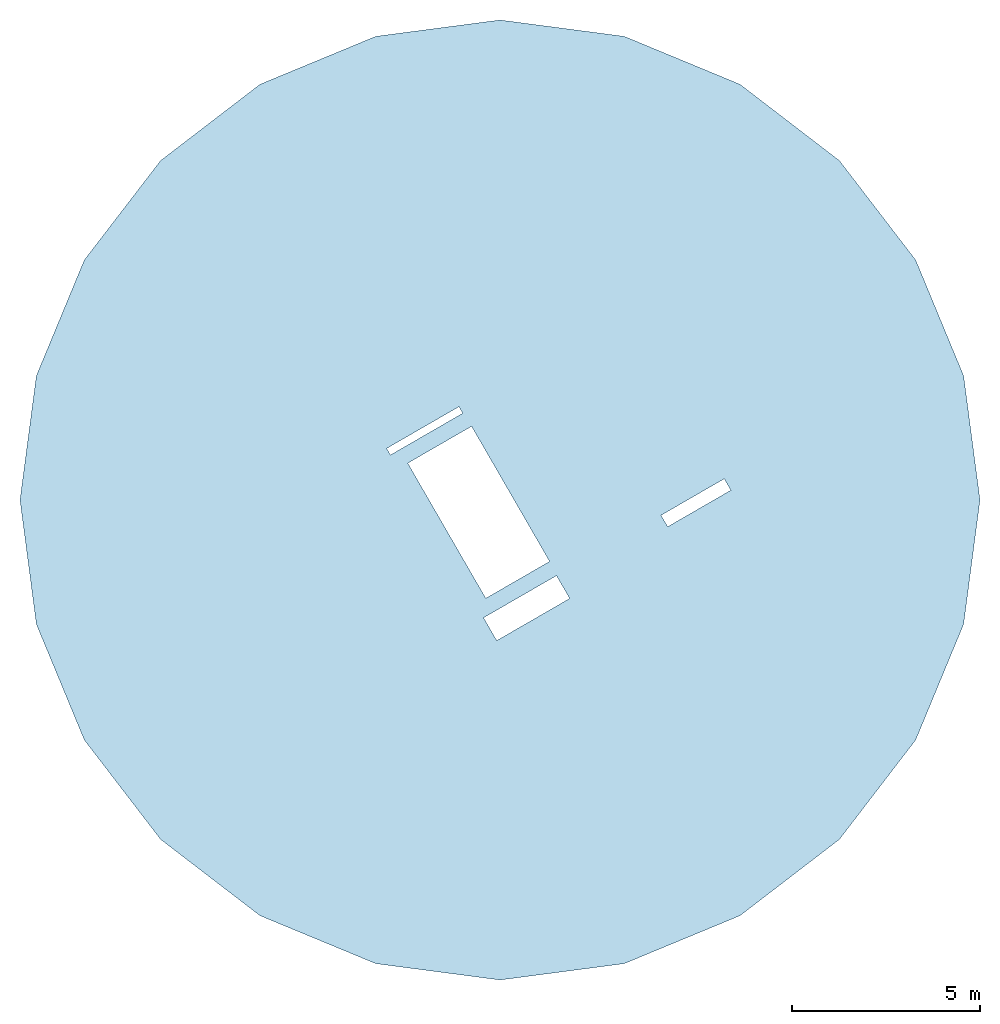
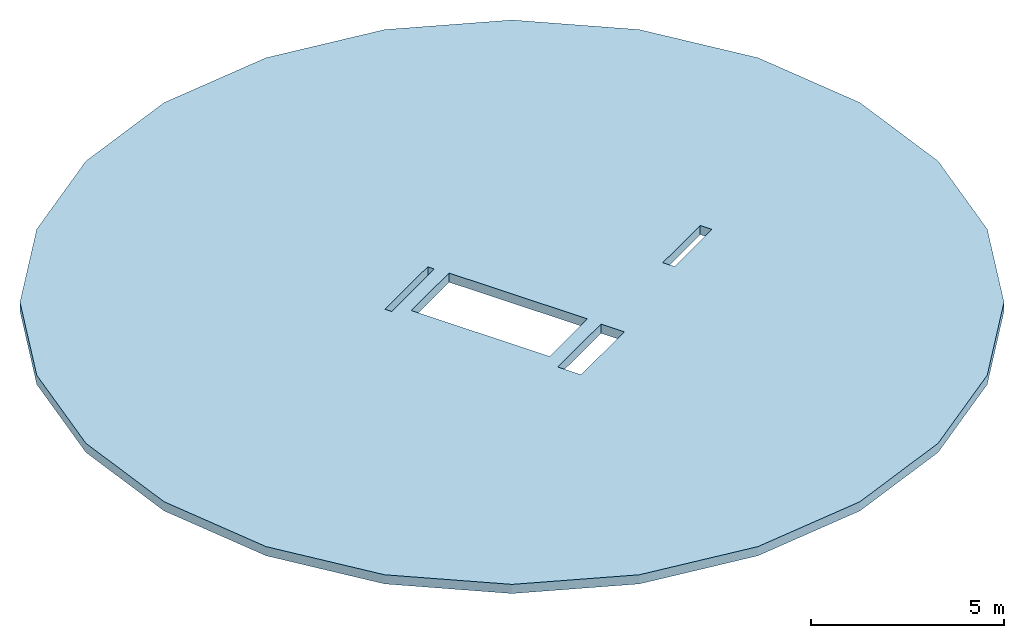
# One storey: 1 slab, 4 openings.
"""IFC2X3 building model written with IfcOpenShell, lengths in millimetres."""

from ifc_helpers import new_model, entity, si_unit, converted_unit, derived_unit, direction, frame, frame_2d, origin, origin_with_axes, place, context, subcontext, project, spatial, polyline, rectangle, outline, extrude, material, layer, layer_set, layer_usage, type_object, element, save


model = new_model("IFC2X3")

# Units and contexts
model_context = context("Model", 3, precision=0.01, world=origin(), true_north=direction((6.12303176911189e-17, 1.0)))
plan_context = context("Plan", 3, precision=0.01, world=origin(), true_north=direction((6.12303176911189e-17, 1.0)))
body_context = subcontext(model_context, "Body", "Model", "MODEL_VIEW")
ifc_project = project(units=[converted_unit("PLANEANGLEUNIT", "DEGREE", entity("IfcPositiveLengthMeasure", 0.0174532925239284), si_unit("PLANEANGLEUNIT", "RADIAN"), dimensions=[0, 0, 0, 0, 0, 0, 0]), si_unit("AREAUNIT", "SQUARE_METRE", prefix="MILLI"), si_unit("LENGTHUNIT", "METRE", prefix="MILLI"), si_unit("MASSUNIT", "GRAM", prefix="KILO"), si_unit("POWERUNIT", "WATT"), si_unit("PRESSUREUNIT", "PASCAL"), si_unit("FORCEUNIT", "NEWTON", prefix="KILO"), si_unit("ELECTRICVOLTAGEUNIT", "VOLT"), si_unit("ELECTRICCURRENTUNIT", "AMPERE"), si_unit("THERMODYNAMICTEMPERATUREUNIT", "DEGREE_CELSIUS"), si_unit("TIMEUNIT", "SECOND"), si_unit("VOLUMEUNIT", "CUBIC_METRE", prefix="MILLI"), derived_unit("LINEARVELOCITYUNIT", [(si_unit("LENGTHUNIT", "METRE"), 1), (si_unit("TIMEUNIT", "SECOND"), -1)]), derived_unit("VOLUMETRICFLOWRATEUNIT", [(si_unit("VOLUMEUNIT", "CUBIC_METRE"), 1), (si_unit("TIMEUNIT", "SECOND"), -1)]), derived_unit("THERMALTRANSMITTANCEUNIT", [(si_unit("POWERUNIT", "WATT"), 1), (si_unit("THERMODYNAMICTEMPERATUREUNIT", "KELVIN"), -1), (si_unit("AREAUNIT", "SQUARE_METRE"), -1)]), derived_unit("SOUNDPRESSUREUNIT", [(si_unit("PRESSUREUNIT", "PASCAL"), 1)])], contexts=[model_context, plan_context])

# Site, building, storey
site_placement = place(None, origin_with_axes())
site = spatial("IfcSite", under=ifc_project, at=site_placement, CompositionType="ELEMENT")
building_placement = place(site_placement, origin_with_axes())
building = spatial("IfcBuilding", under=site, at=building_placement, CompositionType="ELEMENT")
storey_placement = place(building_placement, frame((0.0, 0.0, 31510.0), z_axis=(0.0, 0.0, 1.0), x_axis=(1.0, 0.0, 0.0)))
storey = spatial("IfcBuildingStorey", under=building, at=storey_placement, Name="07 zevende verdieping", CompositionType="ELEMENT", Elevation=31510.0)

# Slab, openings
ifc_material = material()
ifc_layer = layer(ifc_material, 290.0)
ifc_layer_set = layer_set([ifc_layer])
ifc_layer_usage = layer_usage(ifc_layer_set, "AXIS3", "POSITIVE", 0.0)
slab_type = type_object("IfcSlabType", PredefinedType="FLOOR", material=ifc_layer_set)
slab_placement = place(storey_placement, frame((8772.28257779156, 8120.75735905521, -290.0), z_axis=(0.0, 0.0, 1.0), x_axis=(1.0, 0.0, 0.0)))
slab = element("IfcSlab", 1, at=slab_placement, inside=storey, type_object=slab_type, material=ifc_layer_usage, PredefinedType="FLOOR", context=body_context, shape_type="SweptSolid", body=[
    extrude(outline(polyline([(9029.21806202841, -9029.21806202847), (11058.4885141456, -6384.62132047238), (12334.1412490402, -3304.92318701166), (12769.2426409447, 0.0), (12334.1412490401, 3304.92318701174), (11058.4885141456, 6384.62132047241), (9029.21806202842, 9029.21806202845), (6384.62132047233, 11058.4885141456), (3304.92318701168, 12334.1412490401), (0.0, 12769.2426409447), (-3304.92318701172, 12334.1412490401), (-6384.6213204724, 11058.4885141456), (-9029.21806202845, 9029.21806202843), (-11058.4885141456, 6384.62132047236), (-12334.1412490401, 3304.9231870117), (-12769.2426409447, 0.0), (-12334.1412490401, -3304.9231870117), (-11058.4885141456, -6384.62132047239), (-9029.21806202846, -9029.21806202842), (-6384.62132047236, -11058.4885141456), (-3304.92318701172, -12334.1412490401), (0.0, -12769.2426409447), (3304.92318701167, -12334.1412490402), (6384.62132047233, -11058.4885141457), (9029.21806202841, -9029.21806202847)])), frame((12769.2426409447, 12769.2426409447, 290.0), z_axis=(0.0, 0.0, -1.0), x_axis=(-1.0, 0.0, 0.0)), (0.0, 0.0, 1.0), 289.999999999999),
])
opening_1_placement = place(slab_placement, origin_with_axes())
element("IfcOpeningElement", 2, at=opening_1_placement, cuts=slab, ObjectType="Opening", context=body_context, shape_type="SweptSolid", body=[
    extrude(outline(polyline([(-979.999997285318, -2075.0), (980.000002617686, -2075.0), (979.99999728522, 2075.0), (-980.000002617592, 2075.0), (-979.999997285318, -2075.0)])), frame((12201.9959998033, 12441.7426383109, 0.0), z_axis=(0.0, 0.0, 1.0), x_axis=(-0.866025404426883, -0.499999998887253, 0.0)), (0.0, 0.0, 1.0), 289.999999999999),
])
opening_2_placement = place(slab_placement, origin_with_axes())
element("IfcOpeningElement", 3, at=opening_2_placement, cuts=slab, ObjectType="Opening", context=body_context, shape_type="SweptSolid", body=[
    extrude(rectangle(XDim=699.999999999994, YDim=2239.99989679083, at=frame_2d((1.08002495835535e-12, 1.93267624126747e-12), x_axis=(1.0, 0.0))), frame((13477.2717540577, 9892.90034139278, 0.0), z_axis=(0.0, 0.0, 1.0), x_axis=(0.499999999999995, -0.866025403784442, 0.0)), (0.0, 0.0, 1.0), 289.999999999999),
])
opening_3_placement = place(slab_placement, origin_with_axes())
element("IfcOpeningElement", 4, at=opening_3_placement, cuts=slab, ObjectType="Opening", context=body_context, shape_type="SweptSolid", body=[
    extrude(rectangle(XDim=1940.0, YDim=350.000000000003, at=frame_2d((-3.75166564481333e-12, 2.1600499167107e-12), x_axis=(1.0, 0.0))), frame((17982.304521587, 12695.9546017145, 0.0), z_axis=(0.0, 0.0, 1.0), x_axis=(-0.866025403784438, -0.500000000000001, 0.0)), (0.0, 0.0, 1.0), 289.999999999999),
])
opening_4_placement = place(slab_placement, origin_with_axes())
element("IfcOpeningElement", 5, at=opening_4_placement, cuts=slab, ObjectType="Opening", context=body_context, shape_type="SweptSolid", body=[
    extrude(rectangle(XDim=199.999999999997, YDim=2219.99999733265, at=frame_2d((1.86162196769146e-12, -1.13686837721616e-12), x_axis=(1.0, 0.0))), frame((10765.9319355858, 14609.0785630295, 0.0), z_axis=(0.0, 0.0, 1.0), x_axis=(0.499999999999991, -0.866025403784444, 0.0)), (0.0, 0.0, 1.0), 289.999999999999),
])

save(model, "model.ifc")
